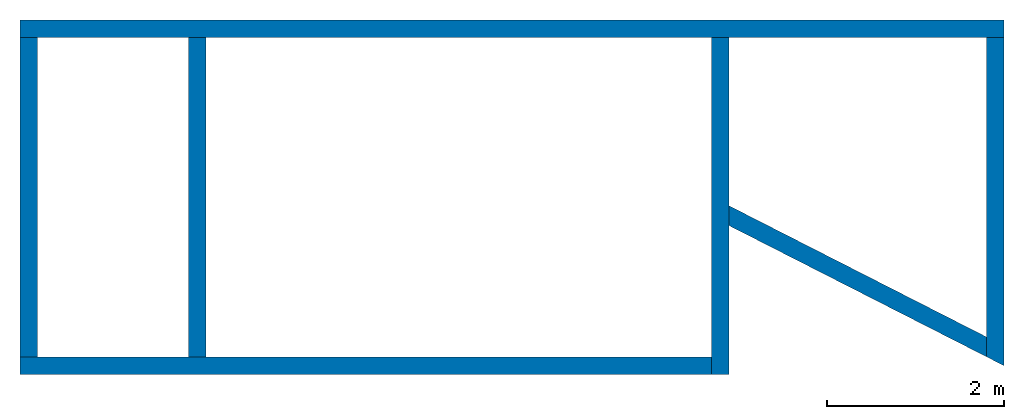
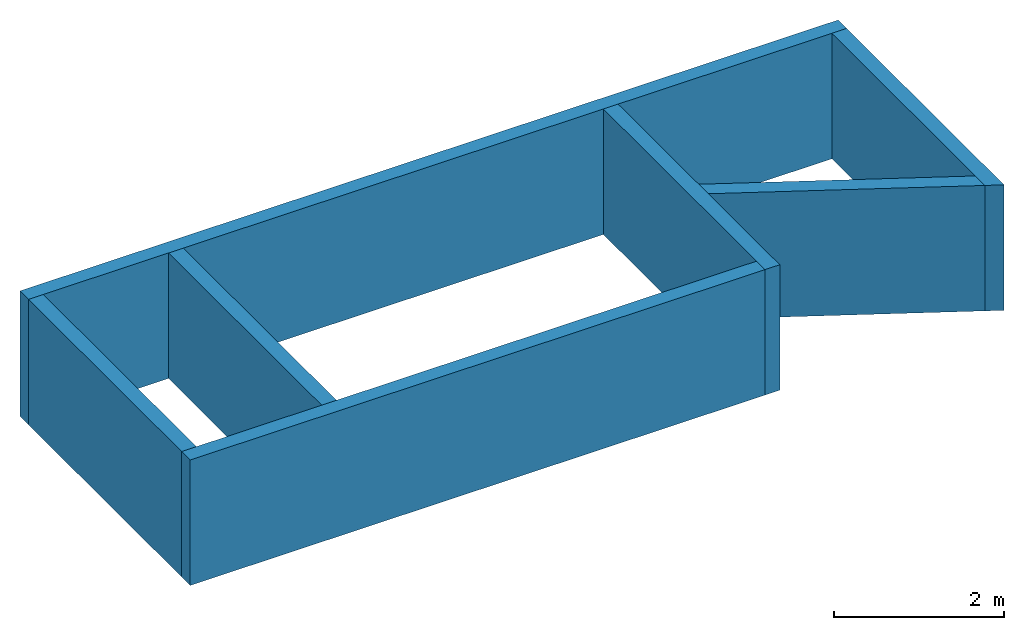
# One storey: 7 walls.
"""IFC2X3 building model written with IfcOpenShell, lengths in millimetres."""

import ifcopenshell
import ifcopenshell.guid

model = None  # the IFC model being written
_history = None  # IfcOwnerHistory: only IFC2X3 demands one
_inside = {}  # id of a spatial element -> (the spatial element, [elements in it])
_under = {}  # id of a project, library or spatial element -> (it, [spatial elements below it])
_declared = {}  # id of a project -> (the project, [libraries it declares])
_typed = {}  # id of a type object -> (the type object, [elements of that type])
_made_of = {}  # id of a material, layer set ... -> (it, [elements and type objects made of it])


def new_model(schema):
    """Start an empty IFC model of exactly this schema.

    Asked for "IFC4X3", IfcOpenShell would pick the latest addendum, in which some entities
    have other attributes; the version numbers below select the first issue.
    IFC2X3 requires an IfcOwnerHistory on every rooted entity: one is made here for all.
    """
    global model, _history
    if schema == "IFC4X3":
        model = ifcopenshell.file(schema_version=(4, 3, 0, 0))
    else:
        model = ifcopenshell.file(schema=schema)
    _inside.clear()
    _under.clear()
    _declared.clear()
    _typed.clear()
    _made_of.clear()
    _history = None
    if model.schema == "IFC2X3":
        org = make("IfcOrganization", Name="unknown")
        user = make(
            "IfcPersonAndOrganization",
            ThePerson=make("IfcPerson", FamilyName="unknown"),
            TheOrganization=org,
        )
        app = make(
            "IfcApplication",
            ApplicationDeveloper=org,
            Version="unknown",
            ApplicationFullName="unknown",
            ApplicationIdentifier="unknown",
        )
        _history = make(
            "IfcOwnerHistory",
            OwningUser=user,
            OwningApplication=app,
            ChangeAction="ADDED",
            CreationDate=0,
        )
    return model


def make(cls, **values):
    """One entity of the class cls with the attributes given. An attribute that is None is left unset."""
    return model.create_entity(
        cls, **{name: value for name, value in values.items() if value is not None}
    )


def entity(cls, *values):
    """Any entity or typed value of the class cls, its attributes in the order of the schema. None: left unset."""
    e = model.create_entity(cls)
    for i, value in enumerate(values):
        if value is not None:
            e[i] = value
    return e


def rooted(cls, **values):
    """An entity with a GlobalId (a new one), such as an element, a storey or a relation."""
    return make(cls, GlobalId=ifcopenshell.guid.new(), OwnerHistory=_history, **values)


def si_unit(unit_type, name, prefix=None):
    """IfcSIUnit, for example si_unit("LENGTHUNIT", "METRE", prefix="MILLI")."""
    return make("IfcSIUnit", UnitType=unit_type, Prefix=prefix, Name=name)


def converted_unit(unit_type, name, factor, base, dimensions=None, offset=None):
    """IfcConversionBasedUnit, such as the inch: factor (a typed value) times the base unit."""
    return make(
        "IfcConversionBasedUnit"
        if offset is None
        else "IfcConversionBasedUnitWithOffset",
        ConversionOffset=offset,
        Dimensions=None
        if dimensions is None
        else entity("IfcDimensionalExponents", *dimensions),
        UnitType=unit_type,
        Name=name,
        ConversionFactor=make(
            "IfcMeasureWithUnit", ValueComponent=factor, UnitComponent=base
        ),
    )


def derived_unit(unit_type, elements):
    """IfcDerivedUnit: a product of units, each with its exponent."""
    return make(
        "IfcDerivedUnit",
        Elements=[
            make("IfcDerivedUnitElement", Unit=unit, Exponent=power)
            for unit, power in elements
        ],
        UnitType=unit_type,
    )


def assignment(units):
    """IfcUnitAssignment: the units of a project."""
    return None if units is None else make("IfcUnitAssignment", Units=units)


def point(xyz):
    """IfcCartesianPoint."""
    return None if xyz is None else make("IfcCartesianPoint", Coordinates=xyz)


def direction(xyz):
    """IfcDirection."""
    return None if xyz is None else make("IfcDirection", DirectionRatios=xyz)


def frame(location, z_axis=None, x_axis=None):
    """IfcAxis2Placement3D, a coordinate frame: its origin and axes. An axis left out is left unset."""
    return make(
        "IfcAxis2Placement3D",
        Location=point(location),
        Axis=direction(z_axis),
        RefDirection=direction(x_axis),
    )


def frame_2d(location, x_axis=None):
    """IfcAxis2Placement2D, a coordinate frame in the plane: its origin and x axis."""
    return make(
        "IfcAxis2Placement2D", Location=point(location), RefDirection=direction(x_axis)
    )


def origin():
    """The frame at (0, 0, 0) with its axes left unset."""
    return frame((0.0, 0.0, 0.0))


def place(relative_to, where):
    """IfcLocalPlacement: puts the frame where relative to a parent placement (None: the world)."""
    return make(
        "IfcLocalPlacement", PlacementRelTo=relative_to, RelativePlacement=where
    )


def context(
    kind, dimensions, precision=None, world=None, true_north=None, identifier=None
):
    """IfcGeometricRepresentationContext, for example the 3D "Model" context."""
    return make(
        "IfcGeometricRepresentationContext",
        ContextIdentifier=identifier,
        ContextType=kind,
        CoordinateSpaceDimension=dimensions,
        Precision=precision,
        WorldCoordinateSystem=world,
        TrueNorth=true_north,
    )


def subcontext(parent, identifier, kind, view, scale=None):
    """IfcGeometricRepresentationSubContext, for example "Body" below "Model"."""
    return make(
        "IfcGeometricRepresentationSubContext",
        ContextIdentifier=identifier,
        ContextType=kind,
        ParentContext=parent,
        TargetScale=scale,
        TargetView=view,
    )


def project(units=None, contexts=None):
    """IfcProject with its units and contexts."""
    return rooted(
        "IfcProject",
        Name="project",
        RepresentationContexts=contexts,
        UnitsInContext=assignment(units),
    )


def spatial(cls, under=None, at=None, **own):
    """A site, building, storey or space (cls), placed at a placement, below another one or the project."""
    s = rooted(cls, ObjectPlacement=at, **own)
    if under is not None:
        _under.setdefault(under.id(), (under, []))[1].append(s)
    return s


def polyline(points):
    """IfcPolyline through the points."""
    return make("IfcPolyline", Points=[point(p) for p in points])


def profile(cls, at=None, kind="AREA", **sizes):
    """A parametric profile (cls). Its sizes go by their IFC names, for example OverallWidth=200.0."""
    return make(cls, ProfileType=kind, Position=at, **sizes)


def rectangle(**sizes):
    """IfcRectangleProfileDef."""
    return profile("IfcRectangleProfileDef", **sizes)


def outline(outer, holes=None, kind="AREA"):
    """IfcArbitraryClosedProfileDef: a profile drawn as a closed curve; with holes, ...WithVoids."""
    if holes is None:
        return make("IfcArbitraryClosedProfileDef", ProfileType=kind, OuterCurve=outer)
    return make(
        "IfcArbitraryProfileDefWithVoids",
        ProfileType=kind,
        OuterCurve=outer,
        InnerCurves=holes,
    )


def extrude(swept, where, along, depth):
    """IfcExtrudedAreaSolid: the profile swept, set in the frame where, extruded along a direction by depth."""
    return make(
        "IfcExtrudedAreaSolid",
        SweptArea=swept,
        Position=where,
        ExtrudedDirection=direction(along),
        Depth=depth,
    )


def shape(context_of_items, identifier, shape_type, items):
    """IfcShapeRepresentation: the items that make up one representation, for example the "Body"."""
    return make(
        "IfcShapeRepresentation",
        ContextOfItems=context_of_items,
        RepresentationIdentifier=identifier,
        RepresentationType=shape_type,
        Items=items,
    )


def material(Name=None, Category=None):
    """IfcMaterial."""
    return make("IfcMaterial", Name=Name, Category=Category)


def layer(
    of_material, thickness, ventilated=None, Name=None, Category=None, Priority=None
):
    """IfcMaterialLayer: one layer of a wall or slab, of a material (None: an air gap)."""
    return make(
        "IfcMaterialLayer",
        Material=of_material,
        LayerThickness=thickness,
        IsVentilated=ventilated,
        Name=Name,
        Category=Category,
        Priority=Priority,
    )


def layer_set(layers, Name=None):
    """IfcMaterialLayerSet."""
    return make("IfcMaterialLayerSet", MaterialLayers=layers, LayerSetName=Name)


def layer_usage(for_layer_set, set_direction, sense, offset, extent=None):
    """IfcMaterialLayerSetUsage: how a layer set lies in its element."""
    return make(
        "IfcMaterialLayerSetUsage",
        ForLayerSet=for_layer_set,
        LayerSetDirection=set_direction,
        DirectionSense=sense,
        OffsetFromReferenceLine=offset,
        ReferenceExtent=extent,
    )


def made_of(thing, what):
    """Note that an element or type object is made of a material, layer set ...; save() writes the relation."""
    if what is not None:
        _made_of.setdefault(what.id(), (what, []))[1].append(thing)
    return thing


def type_object(cls, material=None, **own):
    """A type object (cls), such as IfcWallType, which elements share."""
    return made_of(rooted(cls, **own), material)


def element(
    cls,
    number,
    at=None,
    inside=None,
    cuts=None,
    type_object=None,
    material=None,
    context=None,
    identifier="Body",
    shape_type=None,
    held_by="IfcProductDefinitionShape",
    body=None,
    shapes=None,
    **own,
):
    """One element of the class cls, such as IfcWall. Its Tag is "e" and its number.

    at: its placement. inside: the storey or other place that contains it. cuts: it is an
    opening in that element (IfcRelVoidsElement). A single representation is given by context,
    identifier, shape_type and body (its items); several are given by shapes. held_by: the class
    of the entity that holds the representations. save() writes the other relations.
    """
    e = rooted(cls, Tag="e%d" % number, ObjectPlacement=at, **own)
    if body is not None:
        shapes = [shape(context, identifier, shape_type, body)]
    if shapes is not None:
        e.Representation = make(held_by, Representations=shapes)
    if inside is not None:
        _inside.setdefault(inside.id(), (inside, []))[1].append(e)
    if cuts is not None:
        rooted(
            "IfcRelVoidsElement", RelatingBuildingElement=cuts, RelatedOpeningElement=e
        )
    if type_object is not None:
        _typed.setdefault(type_object.id(), (type_object, []))[1].append(e)
    return made_of(e, material)


def aggregate(whole, parts):
    """IfcRelAggregates: a whole, such as a stair, and the parts it consists of."""
    return rooted("IfcRelAggregates", RelatingObject=whole, RelatedObjects=parts)


def save(model, path):
    """Write the relations noted so far, then the file.

    IfcRelAggregates (storeys below a building ...), IfcRelContainedInSpatialStructure (elements
    in a storey), IfcRelDefinesByType, IfcRelAssociatesMaterial and IfcRelDeclares: one each for
    every whole, place, type object, material and project.
    """
    for whole, parts in _under.values():
        aggregate(whole, parts)
    for where, things in _inside.values():
        rooted(
            "IfcRelContainedInSpatialStructure",
            RelatedElements=things,
            RelatingStructure=where,
        )
    for kind, things in _typed.values():
        rooted("IfcRelDefinesByType", RelatedObjects=things, RelatingType=kind)
    for what, things in _made_of.values():
        rooted("IfcRelAssociatesMaterial", RelatedObjects=things, RelatingMaterial=what)
    for by, libraries in _declared.values():
        rooted("IfcRelDeclares", RelatingContext=by, RelatedDefinitions=libraries)
    model.write(path)


model = new_model("IFC2X3")

# Units and contexts
model_context = context("Model", 3, precision=1e-06, world=origin(), true_north=direction((2.0, 6.12303176911189e-17, 1.0)))
context_of_model = context(None, 3, precision=1e-06, world=origin(), true_north=direction((2.0, 6.12303176911189e-17, 1.0)))
body_context = subcontext(model_context, "Body", "Model", "MODEL_VIEW")
ifc_project = project(units=[si_unit("LENGTHUNIT", "METRE", prefix="MILLI"), si_unit("AREAUNIT", "SQUARE_METRE", prefix="MILLI"), si_unit("VOLUMEUNIT", "CUBIC_METRE", prefix="MILLI"), converted_unit("PLANEANGLEUNIT", "DEGREE", entity("IfcRatioMeasure", 0.0174532925199433), si_unit("PLANEANGLEUNIT", "RADIAN"), dimensions=[0, 0, 0, 0, 0, 0, 0]), si_unit("TIMEUNIT", "SECOND"), si_unit("THERMODYNAMICTEMPERATUREUNIT", "KELVIN"), derived_unit("THERMALTRANSMITTANCEUNIT", [(si_unit("MASSUNIT", "GRAM", prefix="KILO"), 1), (si_unit("THERMODYNAMICTEMPERATUREUNIT", "KELVIN"), -1), (si_unit("TIMEUNIT", "SECOND"), -3)]), derived_unit("VOLUMETRICFLOWRATEUNIT", [(si_unit("LENGTHUNIT", "METRE"), 3), (si_unit("TIMEUNIT", "SECOND"), -1)]), si_unit("POWERUNIT", "WATT"), converted_unit("MASSUNIT", "pound", entity("IfcRatioMeasure", 0.45359237), si_unit("MASSUNIT", "GRAM", prefix="KILO"), dimensions=[0, 1, 0, 0, 0, 0, 0]), si_unit("ILLUMINANCEUNIT", "LUX")], contexts=[model_context, context_of_model])

# Site, building, storey
site_placement = place(None, origin())
site = spatial("IfcSite", under=ifc_project, at=site_placement, CompositionType="ELEMENT")
building_placement = place(site_placement, origin())
building = spatial("IfcBuilding", under=site, at=building_placement, CompositionType="ELEMENT")
storey_placement = place(building_placement, origin())
storey = spatial("IfcBuildingStorey", under=building, at=storey_placement, Name="Level 1", CompositionType="ELEMENT", Elevation=0.0)

# Walls
ifc_material = material(Name="Default Wall")
ifc_layer = layer(ifc_material, 200.0)
ifc_layer_set = layer_set([ifc_layer], Name="Basic Wall:Generic - 200mm_boundary1")
ifc_layer_usage_1 = layer_usage(ifc_layer_set, "AXIS2", "NEGATIVE", 100.0)
wall_type = type_object("IfcWallType", Name="Basic Wall:Generic - 200mm_boundary1", PredefinedType="STANDARD", material=ifc_layer_set)
wall_1_placement = place(storey_placement, frame((-18672.6331931545, 1965.86639666209, 0.0)))
element("IfcWallStandardCase", 1, at=wall_1_placement, inside=storey, type_object=wall_type, material=ifc_layer_usage_1, Name="Basic Wall:Generic - 200mm_boundary1", ObjectType="Basic Wall:Generic - 200mm_boundary1", context=body_context, shape_type="SweptSolid", body=[
    extrude(rectangle(XDim=11100.0, YDim=200.0, at=frame_2d((5550.0, 2.8421709430404e-14), x_axis=(-1.0, 0.0))), origin(), (0.0, 0.0, 1.0), 1800.0),
])
ifc_layer_usage_2 = layer_usage(ifc_layer_set, "AXIS2", "NEGATIVE", 100.0)
wall_2_placement = place(storey_placement, frame((-10772.6331931545, 1865.86639666207, 0.0), z_axis=(0.0, 0.0, 1.0), x_axis=(0.0, -1.0, 0.0)))
element("IfcWallStandardCase", 2, at=wall_2_placement, inside=storey, type_object=wall_type, material=ifc_layer_usage_2, Name="Basic Wall:Generic - 200mm_boundary1", ObjectType="Basic Wall:Generic - 200mm_boundary1", context=body_context, shape_type="SweptSolid", body=[
    extrude(rectangle(XDim=3800.0, YDim=199.999999999998, at=frame_2d((1900.0, 0.0), x_axis=(-1.0, 0.0))), origin(), (0.0, 0.0, 1.0), 1800.0),
])
ifc_layer_usage_3 = layer_usage(ifc_layer_set, "AXIS2", "NEGATIVE", 100.0)
wall_3_placement = place(storey_placement, frame((-10872.6331931545, -1834.13360333793, 0.0), z_axis=(0.0, 0.0, 1.0), x_axis=(-1.0, 0.0, 0.0)))
element("IfcWallStandardCase", 3, at=wall_3_placement, inside=storey, type_object=wall_type, material=ifc_layer_usage_3, Name="Basic Wall:Generic - 200mm_boundary1", ObjectType="Basic Wall:Generic - 200mm_boundary1", context=body_context, shape_type="SweptSolid", body=[
    extrude(rectangle(XDim=7800.0, YDim=200.0, at=frame_2d((3900.0, -2.1316282072803e-14), x_axis=(-1.0, 0.0))), origin(), (0.0, 0.0, 1.0), 1800.0),
])
ifc_layer_usage_4 = layer_usage(ifc_layer_set, "AXIS2", "NEGATIVE", 100.0)
wall_4_placement = place(storey_placement, frame((-18572.6331931545, -1734.13360333791, 0.0), z_axis=(0.0, 0.0, 1.0), x_axis=(0.0, 1.0, 0.0)))
element("IfcWallStandardCase", 4, at=wall_4_placement, inside=storey, type_object=wall_type, material=ifc_layer_usage_4, Name="Basic Wall:Generic - 200mm_boundary1", ObjectType="Basic Wall:Generic - 200mm_boundary1", context=body_context, shape_type="SweptSolid", body=[
    extrude(rectangle(XDim=3600.0, YDim=199.999999999998, at=frame_2d((1800.0, -1.70530256582424e-13), x_axis=(-1.0, 0.0))), origin(), (0.0, 0.0, 1.0), 1800.0),
])
ifc_layer_usage_5 = layer_usage(ifc_layer_set, "AXIS2", "NEGATIVE", 100.0)
wall_5_placement = place(storey_placement, frame((-16672.6331931545, 1865.86639666209, 0.0), z_axis=(0.0, 0.0, 1.0), x_axis=(0.0, -1.0, 0.0)))
element("IfcWallStandardCase", 5, at=wall_5_placement, inside=storey, type_object=wall_type, material=ifc_layer_usage_5, Name="Basic Wall:Generic - 200mm_boundary1", ObjectType="Basic Wall:Generic - 200mm_boundary1", context=body_context, shape_type="SweptSolid", body=[
    extrude(rectangle(XDim=3600.0, YDim=199.999999999998, at=frame_2d((1800.0, 0.0), x_axis=(-1.0, 0.0))), origin(), (0.0, 0.0, 1.0), 1800.0),
])
ifc_layer_usage_6 = layer_usage(ifc_layer_set, "AXIS2", "NEGATIVE", 100.0)
wall_6_placement = place(storey_placement, frame((-7672.63319315447, 1865.86639666206, 0.0), z_axis=(0.0, 0.0, 1.0), x_axis=(0.0, -1.0, 0.0)))
element("IfcWallStandardCase", 6, at=wall_6_placement, inside=storey, type_object=wall_type, material=ifc_layer_usage_6, Name="Basic Wall:Generic - 200mm_boundary1", ObjectType="Basic Wall:Generic - 200mm_boundary1", context=body_context, shape_type="SweptSolid", body=[
    extrude(outline(polyline([(3598.09491010111, -100.0), (3700.0, 100.0), (0.0, 100.0), (0.0, -100.0), (3373.62966257424, -100.0), (3598.09491010111, -100.0)])), origin(), (0.0, 0.0, 1.0), 1800.0),
])
ifc_layer_usage_7 = layer_usage(ifc_layer_set, "AXIS2", "NEGATIVE", 100.0)
wall_7_placement = place(storey_placement, frame((-7727.23414318052, -1643.12786102022, 0.0), z_axis=(0.0, 0.0, 1.0), x_axis=(-0.891006524188367, 0.453990499739549, 0.0)))
element("IfcWallStandardCase", 7, at=wall_7_placement, inside=storey, type_object=wall_type, material=ifc_layer_usage_7, Name="Basic Wall:Generic - 200mm_boundary1", ObjectType="Basic Wall:Generic - 200mm_boundary1", context=body_context, shape_type="SweptSolid", body=[
    extrude(outline(polyline([(3356.65117903853, -100.0), (3254.74608913964, 100.0), (0.0, 100.0), (101.905089898885, -100.0), (3356.65117903853, -100.0)])), origin(), (0.0, 0.0, 1.0), 1800.0),
])

save(model, "model.ifc")
